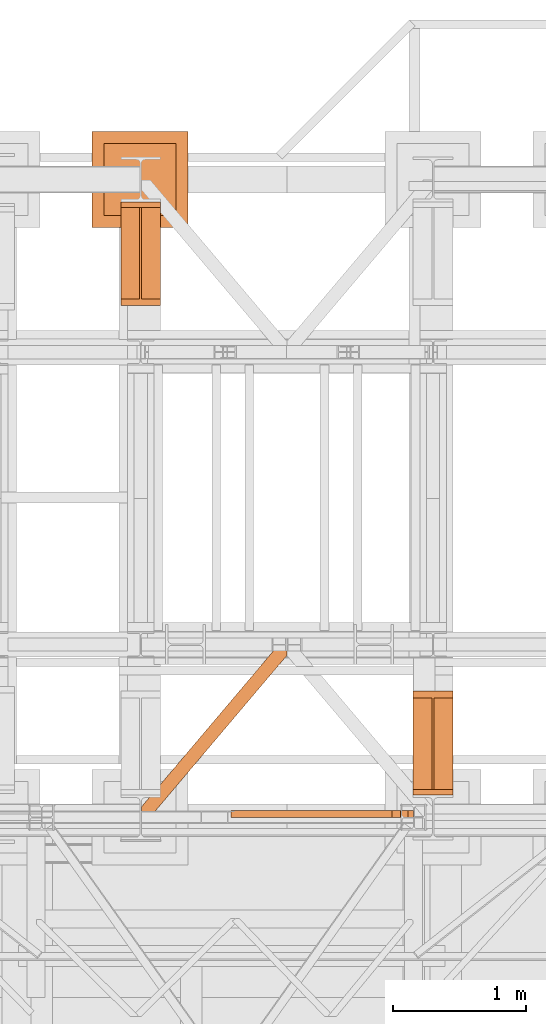
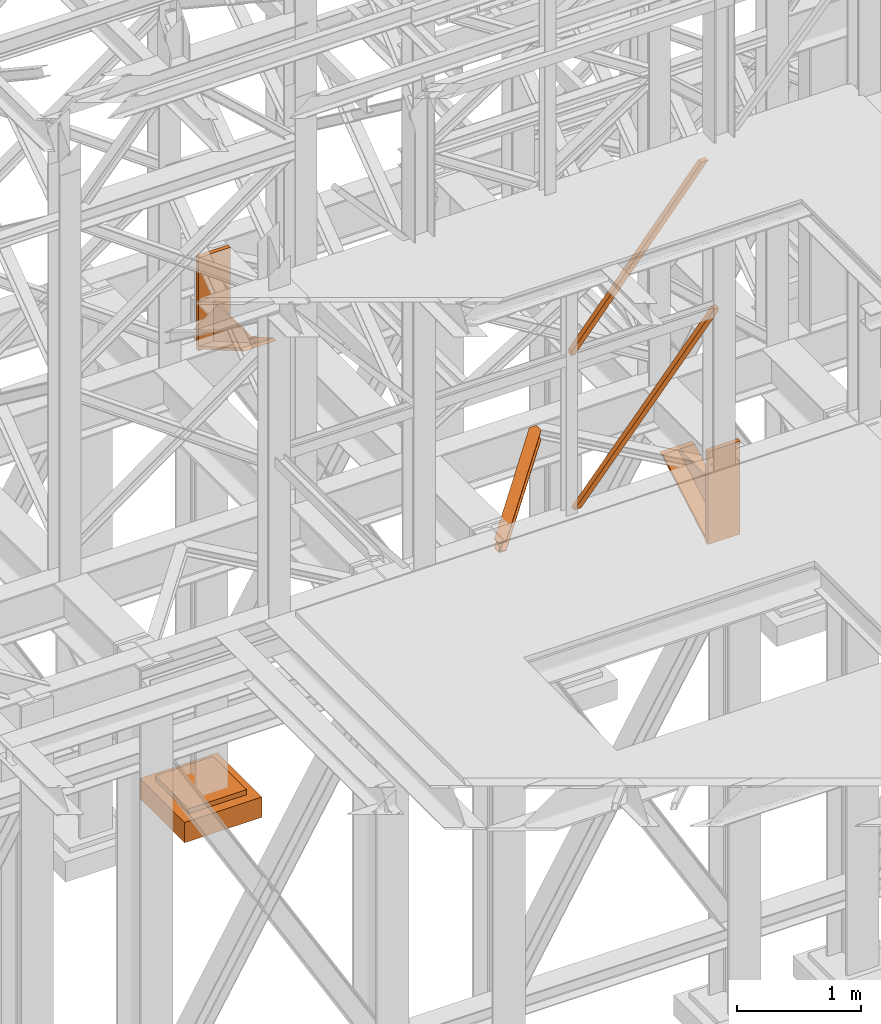
# One storey, part 143 of 208: 6 proxies.
"""IFC2X3 building model written with IfcOpenShell, lengths in millimetres."""

from ifc_helpers import new_model, entity, si_unit, converted_unit, frame, origin, origin_with_axes, place, context, subcontext, project, spatial, faceted_brep, element, save


model = new_model("IFC2X3")

# Units and contexts
model_context = context("Model", 3, precision=1e-05, world=origin())
plan_context = context("Plan", 3, precision=1e-05, world=origin())
body_context = subcontext(model_context, "Body", "Model", "MODEL_VIEW")
ifc_project = project(units=[si_unit("LENGTHUNIT", "METRE", prefix="MILLI"), converted_unit("PLANEANGLEUNIT", "DEGREE", entity("IfcPlaneAngleMeasure", 0.0174532925199433), si_unit("PLANEANGLEUNIT", "RADIAN"), dimensions=[0, 0, 0, 0, 0, 0, 0]), si_unit("AREAUNIT", "SQUARE_METRE"), si_unit("VOLUMEUNIT", "CUBIC_METRE")], contexts=[model_context, plan_context])

# Building, storey
building_placement = place(None, origin())
building = spatial("IfcBuilding", under=ifc_project, at=building_placement, CompositionType="COMPLEX")
storey_placement = place(building_placement, origin_with_axes())
storey = spatial("IfcBuildingStorey", under=building, at=storey_placement, Name="Geschoss", CompositionType="ELEMENT")

# Proxies
proxy_1_placement = place(storey_placement, frame((5343.254974489131, -17092.57439173937, 4367.230005364415), z_axis=(0.0, 0.0, 1.0), x_axis=(1.0, 0.0, 0.0)))
element("IfcBuildingElementProxy", 1, at=proxy_1_placement, inside=storey, context=body_context, shape_type="Brep", body=[
    faceted_brep([(0.01000000000021828, 40.0099999999984, 18.61000000000058), (300.0100000000002, 40.0099999999984, 18.61000000000058), (300.0100000000002, 779.8719999999976, 445.7700000000004), (0.01000000000021828, 779.8719999999976, 445.7700000000004), (0.01000000000021828, 779.8719999999976, 445.7700000000004), (300.0100000000002, 779.8719999999976, 445.7700000000004), (300.0100000000002, 729.8159999999989, 445.7710000000006), (157.5100000000002, 729.8159999999989, 445.7710000000006), (157.5100000000002, 40.0099999999984, 445.7700000000004), (142.5100000000002, 40.0099999999984, 445.7700000000004), (142.5100000000002, 729.8159999999989, 445.7710000000006), (0.01000000000021828, 729.8159999999989, 445.7710000000006), (0.01000000000021828, 729.8159999999989, 445.7710000000006), (142.5100000000002, 729.8159999999989, 445.7710000000006), (142.5100000000002, 40.0099999999984, 47.51000000000022), (0.01000000000021828, 40.0099999999984, 47.51000000000022), (157.5100000000002, 40.0099999999984, 47.51000000000022), (157.5100000000002, 729.8159999999989, 445.7710000000006), (300.0100000000002, 729.8159999999989, 445.7710000000006), (300.0100000000002, 40.0099999999984, 47.51000000000022), (0.01000000000021828, 40.0099999999984, 18.61000000000058), (0.01000000000021828, 779.8719999999976, 445.7700000000004), (0.01000000000021828, 729.8159999999989, 445.7710000000006), (0.01000000000021828, 40.0099999999984, 47.51000000000022), (0.01000000000021828, 40.0099999999984, 917.7700000000004), (0.01000000000021828, 0.00999999999839929, 917.7700000000004), (0.01000000000021828, 0.00999999999839929, 0.01000000000021828), (0.01000000000021828, 40.0099999999984, 0.01000000000021828), (300.0100000000002, 0.00999999999839929, 917.7700000000004), (300.0100000000002, 40.0099999999984, 917.7700000000004), (300.0100000000002, 40.0099999999984, 47.51000000000022), (300.0100000000002, 729.8159999999989, 445.7710000000006), (300.0100000000002, 779.8719999999976, 445.7700000000004), (300.0100000000002, 40.0099999999984, 18.61000000000058), (300.0100000000002, 40.0099999999984, 0.01000000000021828), (300.0100000000002, 0.00999999999839929, 0.01000000000021828), (300.0100000000002, 0.00999999999839929, 917.7700000000004), (0.01000000000021828, 0.00999999999839929, 917.7700000000004), (0.01000000000021828, 40.0099999999984, 917.7700000000004), (300.0100000000002, 40.0099999999984, 917.7700000000004), (300.0100000000002, 40.0099999999984, 917.7700000000004), (0.01000000000021828, 40.0099999999984, 917.7700000000004), (0.01000000000021828, 40.0099999999984, 47.51000000000022), (142.5100000000002, 40.0099999999984, 47.51000000000022), (142.5100000000002, 40.0099999999984, 445.7700000000004), (157.5100000000002, 40.0099999999984, 445.7700000000004), (157.5100000000002, 40.0099999999984, 47.51000000000022), (300.0100000000002, 40.0099999999984, 47.51000000000022), (300.0100000000002, 40.0099999999984, 18.61000000000058), (0.01000000000021828, 40.0099999999984, 18.61000000000058), (0.01000000000021828, 40.0099999999984, 0.01000000000021828), (300.0100000000002, 40.0099999999984, 0.01000000000021828), (300.0100000000002, 40.0099999999984, 0.01000000000021828), (0.01000000000021828, 40.0099999999984, 0.01000000000021828), (0.01000000000021828, 0.00999999999839929, 0.01000000000021828), (300.0100000000002, 0.00999999999839929, 0.01000000000021828), (300.0100000000002, 0.00999999999839929, 0.01000000000021828), (0.01000000000021828, 0.00999999999839929, 0.01000000000021828), (0.01000000000021828, 0.00999999999839929, 917.7700000000004), (300.0100000000002, 0.00999999999839929, 917.7700000000004), (142.5100000000002, 40.0099999999984, 47.51000000000022), (142.5100000000002, 729.8159999999989, 445.7710000000006), (142.5100000000002, 40.0099999999984, 445.7700000000004), (157.5100000000002, 40.0099999999984, 47.51000000000022), (157.5100000000002, 40.0099999999984, 445.7700000000004), (157.5100000000002, 729.8159999999989, 445.7710000000006)], [[[0, 1, 2, 3]], [[4, 5, 6, 7, 8, 9, 10, 11]], [[12, 13, 14, 15]], [[16, 17, 18, 19]], [[20, 21, 22, 23, 24, 25, 26, 27]], [[28, 29, 30, 31, 32, 33, 34, 35]], [[36, 37, 38, 39]], [[40, 41, 42, 43, 44, 45, 46, 47]], [[48, 49, 50, 51]], [[52, 53, 54, 55]], [[56, 57, 58, 59]], [[60, 61, 62]], [[63, 64, 65]]], orient=[[False], [False], [False], [False], [False], [False], [False], [False], [False], [False], [False], [False], [False]]),
])
proxy_2_placement = place(storey_placement, frame((3143.254962568203, -13412.43639531566, 4367.230005364415), z_axis=(0.0, 0.0, 1.0), x_axis=(1.0, 0.0, 0.0)))
element("IfcBuildingElementProxy", 2, at=proxy_2_placement, inside=storey, context=body_context, shape_type="Brep", body=[
    faceted_brep([(0.01000000000021828, 739.8720000000012, 18.61000000000058), (0.01000000000021828, 0.01000000000021828, 445.7700000000004), (300.0100000000002, 0.01000000000021828, 445.7700000000004), (300.0100000000002, 739.8720000000012, 18.61000000000058), (0.01000000000021828, 0.01000000000021828, 445.7700000000004), (0.01000000000021828, 50.06600000000071, 445.7710000000006), (142.5100000000002, 50.06599999999889, 445.7710000000006), (142.5100000000002, 739.8720000000012, 445.7700000000004), (157.5100000000002, 739.8720000000012, 445.7700000000004), (157.5100000000002, 50.06599999999889, 445.7710000000006), (300.0100000000002, 50.06599999999889, 445.7710000000006), (300.0100000000002, 0.01000000000021828, 445.7700000000004), (0.01000000000021828, 50.06600000000071, 445.7710000000006), (0.01000000000021828, 739.8720000000012, 47.51000000000022), (142.5100000000002, 739.8720000000012, 47.51000000000022), (142.5100000000002, 50.06599999999889, 445.7710000000006), (157.5100000000002, 739.8720000000012, 47.51000000000022), (300.0100000000002, 739.8720000000012, 47.51000000000022), (300.0100000000002, 50.06599999999889, 445.7710000000006), (157.5100000000002, 50.06599999999889, 445.7710000000006), (0.01000000000021828, 739.8720000000012, 18.61000000000058), (0.01000000000021828, 739.8720000000012, 0.01000000000021828), (0.01000000000021828, 779.8720000000012, 0.01000000000021828), (0.01000000000021828, 779.8720000000012, 917.7700000000013), (0.01000000000021828, 739.8720000000012, 917.7700000000013), (0.01000000000021828, 739.8720000000012, 47.51000000000022), (0.01000000000021828, 50.06600000000071, 445.7710000000006), (0.01000000000021828, 0.01000000000021828, 445.7700000000004), (300.0100000000002, 779.8719999999994, 917.7700000000013), (300.0100000000002, 779.8720000000012, 0.01000000000021828), (300.0100000000002, 739.8720000000012, 0.01000000000021828), (300.0100000000002, 739.8720000000012, 18.61000000000058), (300.0100000000002, 0.01000000000021828, 445.7700000000004), (300.0100000000002, 50.06599999999889, 445.7710000000006), (300.0100000000002, 739.8720000000012, 47.51000000000022), (300.0100000000002, 739.8719999999994, 917.7700000000013), (300.0100000000002, 779.8719999999994, 917.7700000000013), (300.0100000000002, 739.8719999999994, 917.7700000000013), (0.01000000000021828, 739.8720000000012, 917.7700000000013), (0.01000000000021828, 779.8720000000012, 917.7700000000013), (300.0100000000002, 739.8719999999994, 917.7700000000013), (300.0100000000002, 739.8720000000012, 47.51000000000022), (157.5100000000002, 739.8720000000012, 47.51000000000022), (157.5100000000002, 739.8720000000012, 445.7700000000004), (142.5100000000002, 739.8720000000012, 445.7700000000004), (142.5100000000002, 739.8720000000012, 47.51000000000022), (0.01000000000021828, 739.8720000000012, 47.51000000000022), (0.01000000000021828, 739.8720000000012, 917.7700000000013), (300.0100000000002, 739.8720000000012, 18.61000000000058), (300.0100000000002, 739.8720000000012, 0.01000000000021828), (0.01000000000021828, 739.8720000000012, 0.01000000000021828), (0.01000000000021828, 739.8720000000012, 18.61000000000058), (300.0100000000002, 739.8720000000012, 0.01000000000021828), (300.0100000000002, 779.8720000000012, 0.01000000000021828), (0.01000000000021828, 779.8720000000012, 0.01000000000021828), (0.01000000000021828, 739.8720000000012, 0.01000000000021828), (300.0100000000002, 779.8720000000012, 0.01000000000021828), (300.0100000000002, 779.8719999999994, 917.7700000000013), (0.01000000000021828, 779.8720000000012, 917.7700000000013), (0.01000000000021828, 779.8720000000012, 0.01000000000021828), (142.5100000000002, 739.8720000000012, 47.51000000000022), (142.5100000000002, 739.8720000000012, 445.7700000000004), (142.5100000000002, 50.06599999999889, 445.7710000000006), (157.5100000000002, 739.8720000000012, 47.51000000000022), (157.5100000000002, 50.06599999999889, 445.7710000000006), (157.5100000000002, 739.8720000000012, 445.7700000000004)], [[[0, 1, 2, 3]], [[4, 5, 6, 7, 8, 9, 10, 11]], [[12, 13, 14, 15]], [[16, 17, 18, 19]], [[20, 21, 22, 23, 24, 25, 26, 27]], [[28, 29, 30, 31, 32, 33, 34, 35]], [[36, 37, 38, 39]], [[40, 41, 42, 43, 44, 45, 46, 47]], [[48, 49, 50, 51]], [[52, 53, 54, 55]], [[56, 57, 58, 59]], [[60, 61, 62]], [[63, 64, 65]]], orient=[[False], [False], [False], [False], [False], [False], [False], [False], [False], [False], [False], [False], [False]]),
])
proxy_3_placement = place(storey_placement, frame((3299.254968580828, -17257.87439359531, 5101.990016164881), z_axis=(0.0, 0.0, 1.0), x_axis=(1.0, 0.0, 0.0)))
element("IfcBuildingElementProxy", 3, at=proxy_3_placement, inside=storey, context=body_context, shape_type="Brep", body=[
    faceted_brep([(1028.512359102908, 1290.610003345228, 8.010001311302403), (0.01000000000021828, 75.10721531451782, 8.010001311303313), (0.01000000000021828, 75.10721531451782, 0.01000000000021828), (1028.512359102908, 1290.610003345228, 0.01000000000021828), (1028.512359102908, 1290.610003345228, 0.01000000000021828), (0.01000000000021828, 75.10721531451782, 0.01000000000021828), (0.01000000000021828, 0.00999999999839929, 0.01000000000021828), (67.46148411605282, 0.00999999999839929, 0.01000000000021828), (1094.009999947844, 1213.20370052848, 0.01000000000021828), (1094.009999947844, 1290.610003345228, 0.01000000000021828), (1094.009999947844, 1213.20370052848, 0.01000000000021828), (67.46148411605282, 0.00999999999839929, 0.01000000000021828), (67.46148411605282, 0.00999999999839929, 8.010001311302403), (1094.009999947846, 1213.203700528482, 8.010001311302403), (1094.009999947846, 1213.203700528482, 8.010001311302403), (67.46148411605282, 0.00999999999839929, 8.010001311302403), (20.95815950654287, 0.00999999999839929, 8.010001311302403), (1094.009999947844, 1268.162175066993, 8.010001311302403), (1094.009999947844, 1268.162175066993, 8.010001311302403), (20.95815950654287, 0.00999999999839929, 8.010001311302403), (12.82264470841801, 0.00999999999839929, 9.253033826351384), (1094.009999947845, 1277.776874373869, 9.253033826351384), (1094.009999947845, 1277.776874373869, 9.253033826351384), (12.82264470841801, 0.00999999999839929, 9.253033826351384), (6.86703880668756, 0.00999999999839929, 13.79946006298087), (1094.009999947845, 1284.815317712277, 13.79946006298087), (1094.009999947845, 1284.815317712277, 13.79946006298087), (6.86703880668756, 0.00999999999839929, 13.79946006298087), (5.23872549636144, 0.00999999999839929, 20.01000141560962), (1094.009999947844, 1286.739687988118, 20.01000141561053), (1094.009999947844, 1286.739687988118, 20.01000141561053), (5.23872549636144, 0.00999999999839929, 20.01000141560962), (5.23872549636144, 0.00999999999839929, 76.01000128150008), (1094.009999947844, 1286.739687988116, 76.01000128150008), (1094.009999947844, 1286.739687988116, 76.01000128150008), (5.23872549636144, 0.00999999999839929, 76.01000128150008), (6.86703880668847, 0.00999999999839929, 82.2205407714846), (1094.009999947845, 1284.815317712277, 82.2205407714846), (1094.009999947845, 1284.815317712277, 82.2205407714846), (6.86703880668847, 0.00999999999839929, 82.2205407714846), (12.82264470841892, 0.00999999999839929, 86.76696700811317), (1094.009999947845, 1277.776874373869, 86.76696700811408), (1094.009999947845, 1277.776874373869, 86.76696700811408), (12.82264470841892, 0.00999999999839929, 86.76696700811317), (20.95815950654469, 0.00999999999839929, 88.00999952316306), (1094.009999947845, 1268.162175066993, 88.00999952316306), (1094.009999947845, 1268.162175066993, 88.00999952316306), (20.95815950654469, 0.00999999999839929, 88.00999952316306), (67.46148411605373, 0.00999999999839929, 88.00999952316397), (1094.009999947845, 1213.20370052848, 88.00999952316306), (1094.009999947845, 1213.20370052848, 88.00999952316306), (67.46148411605373, 0.00999999999839929, 88.00999952316397), (67.46148411605373, 0.00999999999839929, 96.01000083446525), (1094.009999947847, 1213.203700528484, 96.01000083446525), (1094.009999947847, 1213.203700528484, 96.01000083446525), (67.46148411605373, 0.00999999999839929, 96.01000083446525), (0.01000000000021828, 0.00999999999839929, 96.01000083446525), (0.01000000000021828, 75.10721531451418, 96.01000083446525), (1028.512359102909, 1290.610003345228, 96.01000083446525), (1094.009999947846, 1290.610003345228, 96.01000083446525), (1028.512359102909, 1290.610003345228, 96.01000083446525), (0.01000000000021828, 75.10721531451418, 96.01000083446525), (0.01000000000021828, 75.10721531451782, 88.00999952316306), (1028.512359102909, 1290.610003345228, 88.00999952316306), (1028.512359102909, 1290.610003345228, 88.00999952316306), (0.01000000000021828, 75.10721531451782, 88.00999952316306), (0.01000000000021828, 20.14874077600325, 88.00999952316215), (1075.01568371242, 1290.610003345228, 88.00999952316306), (1075.01568371242, 1290.610003345228, 88.00999952316306), (0.01000000000021828, 20.14874077600325, 88.00999952316215), (0.01000000000021828, 10.53404146912726, 86.76696700811499), (1083.151198510545, 1290.610003345228, 86.76696700811408), (1083.151198510545, 1290.610003345228, 86.76696700811408), (0.01000000000021828, 10.53404146912726, 86.76696700811499), (0.01000000000021828, 3.495598130721191, 82.2205407714855), (1089.106804412274, 1290.610003345228, 82.2205407714846), (1089.106804412274, 1290.610003345228, 82.2205407714846), (0.01000000000021828, 3.495598130721191, 82.2205407714855), (0.01000000000021828, 1.571227854878089, 76.01000128150008), (1090.735117722602, 1290.610003345228, 76.01000128150008), (1090.735117722602, 1290.610003345228, 76.01000128150008), (0.01000000000021828, 1.571227854878089, 76.01000128150008), (0.01000000000021828, 1.571227854878089, 20.01000141561053), (1090.735117722601, 1290.610003345228, 20.01000141561053), (1090.735117722601, 1290.610003345228, 20.01000141561053), (0.01000000000021828, 1.571227854878089, 20.01000141561053), (0.01000000000021828, 3.495598130721191, 13.79946006298087), (1089.106804412275, 1290.610003345228, 13.79946006298087), (1089.106804412275, 1290.610003345228, 13.79946006298087), (0.01000000000021828, 3.495598130721191, 13.79946006298087), (0.01000000000021828, 10.53404146912726, 9.253033826351384), (1083.151198510544, 1290.610003345228, 9.253033826351384), (1083.151198510544, 1290.610003345228, 9.253033826351384), (0.01000000000021828, 10.53404146912726, 9.253033826351384), (0.01000000000021828, 20.14874077600325, 8.010001311302403), (1075.015683712418, 1290.610003345228, 8.010001311302403), (1075.015683712418, 1290.610003345228, 8.010001311302403), (0.01000000000021828, 20.14874077600325, 8.010001311302403), (0.01000000000021828, 75.10721531451782, 8.010001311303313), (1028.512359102908, 1290.610003345228, 8.010001311302403), (1094.009999947844, 1213.20370052848, 0.01000000000021828), (1094.009999947846, 1213.203700528482, 8.010001311302403), (1094.009999947844, 1268.162175066993, 8.010001311302403), (1094.009999947845, 1277.776874373869, 9.253033826351384), (1094.009999947845, 1284.815317712277, 13.79946006298087), (1094.009999947844, 1286.739687988118, 20.01000141561053), (1094.009999947844, 1286.739687988116, 76.01000128150008), (1094.009999947845, 1284.815317712277, 82.2205407714846), (1094.009999947845, 1277.776874373869, 86.76696700811408), (1094.009999947845, 1268.162175066993, 88.00999952316306), (1094.009999947845, 1213.20370052848, 88.00999952316306), (1094.009999947847, 1213.203700528484, 96.01000083446525), (1094.009999947846, 1290.610003345228, 96.01000083446525), (1094.009999947844, 1290.610003345228, 0.01000000000021828), (1094.009999947846, 1290.610003345228, 96.01000083446525), (1028.512359102909, 1290.610003345228, 96.01000083446525), (1028.512359102909, 1290.610003345228, 88.00999952316306), (1075.01568371242, 1290.610003345228, 88.00999952316306), (1083.151198510545, 1290.610003345228, 86.76696700811408), (1089.106804412274, 1290.610003345228, 82.2205407714846), (1090.735117722602, 1290.610003345228, 76.01000128150008), (1090.735117722601, 1290.610003345228, 20.01000141561053), (1089.106804412275, 1290.610003345228, 13.79946006298087), (1083.151198510544, 1290.610003345228, 9.253033826351384), (1075.015683712418, 1290.610003345228, 8.010001311302403), (1028.512359102908, 1290.610003345228, 8.010001311302403), (1028.512359102908, 1290.610003345228, 0.01000000000021828), (1094.009999947844, 1290.610003345228, 0.01000000000021828), (0.01000000000021828, 75.10721531451782, 0.01000000000021828), (0.01000000000021828, 75.10721531451782, 8.010001311303313), (0.01000000000021828, 20.14874077600325, 8.010001311302403), (0.01000000000021828, 10.53404146912726, 9.253033826351384), (0.01000000000021828, 3.495598130721191, 13.79946006298087), (0.01000000000021828, 1.571227854878089, 20.01000141561053), (0.01000000000021828, 1.571227854878089, 76.01000128150008), (0.01000000000021828, 3.495598130721191, 82.2205407714855), (0.01000000000021828, 10.53404146912726, 86.76696700811499), (0.01000000000021828, 20.14874077600325, 88.00999952316215), (0.01000000000021828, 75.10721531451782, 88.00999952316306), (0.01000000000021828, 75.10721531451418, 96.01000083446525), (0.01000000000021828, 0.00999999999839929, 96.01000083446525), (0.01000000000021828, 0.00999999999839929, 0.01000000000021828), (67.46148411605282, 0.00999999999839929, 0.01000000000021828), (0.01000000000021828, 0.00999999999839929, 0.01000000000021828), (0.01000000000021828, 0.00999999999839929, 96.01000083446525), (67.46148411605373, 0.00999999999839929, 96.01000083446525), (67.46148411605373, 0.00999999999839929, 88.00999952316397), (20.95815950654469, 0.00999999999839929, 88.00999952316306), (12.82264470841892, 0.00999999999839929, 86.76696700811317), (6.86703880668847, 0.00999999999839929, 82.2205407714846), (5.23872549636144, 0.00999999999839929, 76.01000128150008), (5.23872549636144, 0.00999999999839929, 20.01000141560962), (6.86703880668756, 0.00999999999839929, 13.79946006298087), (12.82264470841801, 0.00999999999839929, 9.253033826351384), (20.95815950654287, 0.00999999999839929, 8.010001311302403), (67.46148411605282, 0.00999999999839929, 8.010001311302403)], [[[0, 1, 2, 3]], [[4, 5, 6, 7, 8, 9]], [[10, 11, 12, 13]], [[14, 15, 16, 17]], [[18, 19, 20, 21]], [[22, 23, 24, 25]], [[26, 27, 28, 29]], [[30, 31, 32, 33]], [[34, 35, 36, 37]], [[38, 39, 40, 41]], [[42, 43, 44, 45]], [[46, 47, 48, 49]], [[50, 51, 52, 53]], [[54, 55, 56, 57, 58, 59]], [[60, 61, 62, 63]], [[64, 65, 66, 67]], [[68, 69, 70, 71]], [[72, 73, 74, 75]], [[76, 77, 78, 79]], [[80, 81, 82, 83]], [[84, 85, 86, 87]], [[88, 89, 90, 91]], [[92, 93, 94, 95]], [[96, 97, 98, 99]], [[100, 101, 102, 103, 104, 105, 106, 107, 108, 109, 110, 111, 112, 113]], [[114, 115, 116, 117, 118, 119, 120, 121, 122, 123, 124, 125, 126, 127]], [[128, 129, 130, 131, 132, 133, 134, 135, 136, 137, 138, 139, 140, 141]], [[142, 143, 144, 145, 146, 147, 148, 149, 150, 151, 152, 153, 154, 155]]], orient=[[False], [False], [False], [False], [False], [False], [False], [False], [False], [False], [False], [False], [False], [False], [False], [False], [False], [False], [False], [False], [False], [False], [False], [False], [False], [False], [False], [False]]),
])
proxy_4_placement = place(storey_placement, frame((3998.254972253957, -17262.57439031789, 5284.990005364416), z_axis=(0.0, 0.0, 1.0), x_axis=(1.0, 0.0, 0.0)))
element("IfcBuildingElementProxy", 4, at=proxy_4_placement, inside=storey, context=body_context, shape_type="Brep", body=[
    faceted_brep([(0.01000000000021828, 50.01000074505646, 0.01000000000021828), (1305.994189593219, 50.01000074505646, 1522.509993890527), (1305.994189593219, 0.00999999999839929, 1522.509993890527), (0.01000000000112777, 0.00999999999839929, 0.009999999999308784), (64.45727517743671, 50.01000074505646, 0.01000000000021828), (1346.759996207655, 50.01000074505646, 1493.39055847232), (1346.759996207655, 50.01000074505646, 1522.509993890527), (1305.994189593219, 50.01000074505646, 1522.509993890527), (0.01000000000021828, 50.01000074505646, 0.01000000000021828), (64.45727517743671, 0.00999999999839929, 0.01000000000021828), (1346.759996207655, 0.00999999999839929, 1493.390558472321), (1346.759996207655, 50.01000074505646, 1493.39055847232), (64.45727517743671, 50.01000074505646, 0.01000000000021828), (0.01000000000112777, 0.00999999999839929, 0.009999999999308784), (1305.994189593219, 0.00999999999839929, 1522.509993890527), (1346.759996207655, 0.00999999999839929, 1522.509993890528), (1346.759996207655, 0.00999999999839929, 1493.390558472321), (64.45727517743671, 0.00999999999839929, 0.01000000000021828), (1305.994189593219, 0.00999999999839929, 1522.509993890527), (1305.994189593219, 50.01000074505646, 1522.509993890527), (1346.759996207655, 50.01000074505646, 1522.509993890527), (1346.759996207655, 0.00999999999839929, 1522.509993890528), (1346.759996207655, 50.01000074505646, 1522.509993890527), (1346.759996207655, 50.01000074505646, 1493.39055847232), (1346.759996207655, 0.00999999999839929, 1493.390558472321), (1346.759996207655, 0.00999999999839929, 1522.509993890528), (0.01000000000021828, 50.01000074505646, 0.01000000000021828), (0.01000000000112777, 0.00999999999839929, 0.009999999999308784), (64.45727517743671, 0.00999999999839929, 0.01000000000021828), (64.45727517743671, 50.01000074505646, 0.01000000000021828)], [[[0, 1, 2, 3]], [[4, 5, 6, 7, 8]], [[9, 10, 11, 12]], [[13, 14, 15, 16, 17]], [[18, 19, 20, 21]], [[22, 23, 24, 25]], [[26, 27, 28, 29]]], orient=[[False], [False], [False], [False], [False], [False], [False]]),
])
proxy_5_placement = place(storey_placement, frame((2927.83388466112, -12822.57439725281, -315.01), z_axis=(0.0, 0.0, 1.0), x_axis=(1.0, 0.0, 0.0)))
element("IfcBuildingElementProxy", 5, at=proxy_5_placement, inside=storey, context=body_context, shape_type="Brep", body=[
    faceted_brep([(630.0100000000002, 630.0100000000002, 250.01), (630.0100000000002, 90.01000000000022, 250.01), (90.01000000000022, 90.01000000000022, 250.01), (90.01000000000022, 630.0100000000002, 250.01), (630.0100000000002, 630.0100000000002, 200.01), (630.0100000000002, 90.01000000000022, 200.01), (630.0100000000002, 90.01000000000022, 250.01), (630.0100000000002, 630.0100000000002, 250.01), (90.01000000000022, 630.0100000000002, 200.01), (630.0100000000002, 630.0100000000002, 200.01), (630.0100000000002, 630.0100000000002, 250.01), (90.01000000000022, 630.0100000000002, 250.01), (90.01000000000022, 90.01000000000022, 200.01), (90.01000000000022, 630.0100000000002, 200.01), (90.01000000000022, 630.0100000000002, 250.01), (90.01000000000022, 90.01000000000022, 250.01), (630.0100000000002, 90.01000000000022, 200.01), (90.01000000000022, 90.01000000000022, 200.01), (90.01000000000022, 90.01000000000022, 250.01), (630.0100000000002, 90.01000000000022, 250.01), (720.0100000000002, 0.01000000000021828, 0.009999999999990905), (720.0100000000002, 720.0100000000002, 0.009999999999990905), (0.01000000000021828, 720.0100000000002, 0.009999999999990905), (0.01000000000021828, 0.01000000000021828, 0.009999999999990905), (720.0100000000002, 720.0100000000002, 200.01), (720.0100000000002, 0.01000000000021828, 200.01), (0.01000000000021828, 0.01000000000021828, 200.01), (0.01000000000021828, 720.0100000000002, 200.01), (90.01000000000022, 90.01000000000022, 200.01), (630.0100000000002, 90.01000000000022, 200.01), (630.0100000000002, 630.0100000000002, 200.01), (90.01000000000022, 630.0100000000002, 200.01), (720.0100000000002, 720.0100000000002, 0.009999999999990905), (720.0100000000002, 0.01000000000021828, 0.009999999999990905), (720.0100000000002, 0.01000000000021828, 200.01), (720.0100000000002, 720.0100000000002, 200.01), (0.01000000000021828, 720.0100000000002, 0.009999999999990905), (720.0100000000002, 720.0100000000002, 0.009999999999990905), (720.0100000000002, 720.0100000000002, 200.01), (0.01000000000021828, 720.0100000000002, 200.01), (0.01000000000021828, 0.01000000000021828, 0.009999999999990905), (0.01000000000021828, 720.0100000000002, 0.009999999999990905), (0.01000000000021828, 720.0100000000002, 200.01), (0.01000000000021828, 0.01000000000021828, 200.01), (720.0100000000002, 0.01000000000021828, 0.009999999999990905), (0.01000000000021828, 0.01000000000021828, 0.009999999999990905), (0.01000000000021828, 0.01000000000021828, 200.01), (720.0100000000002, 0.01000000000021828, 200.01)], [[[0, 1, 2, 3]], [[4, 5, 6, 7]], [[8, 9, 10, 11]], [[12, 13, 14, 15]], [[16, 17, 18, 19]], [[20, 21, 22, 23]], [[24, 25, 26, 27], [28, 29, 30, 31]], [[32, 33, 34, 35]], [[36, 37, 38, 39]], [[40, 41, 42, 43]], [[44, 45, 46, 47]]], orient=[[False], [False], [False], [False], [False], [False], [False, False], [False], [False], [False], [False]]),
])
proxy_6_placement = place(storey_placement, frame((3973.254968901194, -17262.57439031789, 6812.489999254943), z_axis=(0.0, 0.0, 1.0), x_axis=(1.0, 0.0, 0.0)))
element("IfcBuildingElementProxy", 6, at=proxy_6_placement, inside=storey, context=body_context, shape_type="Brep", body=[
    faceted_brep([(0.01000000000112777, 0.00999999999839929, 41.12943667735271), (0.01000000000021828, 50.01000074505646, 41.12943667735271), (1210.316480659596, 50.01000074505646, 1482.510002831213), (1210.316480659596, 0.00999999999839929, 1482.510002831213), (0.01000000000021828, 50.01000074505646, 41.12943667735271), (0.01000000000021828, 50.01000074505646, 0.01000000000021828), (31.01676944585506, 50.01000074505646, 0.01000000000112777), (1274.763755837032, 50.01000074505646, 1482.510002831213), (1210.316480659596, 50.01000074505646, 1482.510002831213), (31.01676944585506, 50.01000074505646, 0.01000000000112777), (31.01676944585506, 0.00999999999839929, 0.01000000000112777), (1274.763755837032, 0.00999999999839929, 1482.510002831213), (1274.763755837032, 50.01000074505646, 1482.510002831213), (0.01000000000021828, 0.00999999999839929, 0.01000000000021828), (0.01000000000112777, 0.00999999999839929, 41.12943667735271), (1210.316480659596, 0.00999999999839929, 1482.510002831213), (1274.763755837032, 0.00999999999839929, 1482.510002831213), (31.01676944585506, 0.00999999999839929, 0.01000000000112777), (1210.316480659596, 0.00999999999839929, 1482.510002831213), (1210.316480659596, 50.01000074505646, 1482.510002831213), (1274.763755837032, 50.01000074505646, 1482.510002831213), (1274.763755837032, 0.00999999999839929, 1482.510002831213), (0.01000000000021828, 50.01000074505646, 0.01000000000021828), (0.01000000000021828, 0.00999999999839929, 0.01000000000021828), (31.01676944585506, 0.00999999999839929, 0.01000000000112777), (31.01676944585506, 50.01000074505646, 0.01000000000112777), (0.01000000000021828, 50.01000074505646, 41.12943667735271), (0.01000000000112777, 0.00999999999839929, 41.12943667735271), (0.01000000000021828, 0.00999999999839929, 0.01000000000021828), (0.01000000000021828, 50.01000074505646, 0.01000000000021828)], [[[0, 1, 2, 3]], [[4, 5, 6, 7, 8]], [[9, 10, 11, 12]], [[13, 14, 15, 16, 17]], [[18, 19, 20, 21]], [[22, 23, 24, 25]], [[26, 27, 28, 29]]], orient=[[False], [False], [False], [False], [False], [False], [False]]),
])

save(model, "model.ifc")
